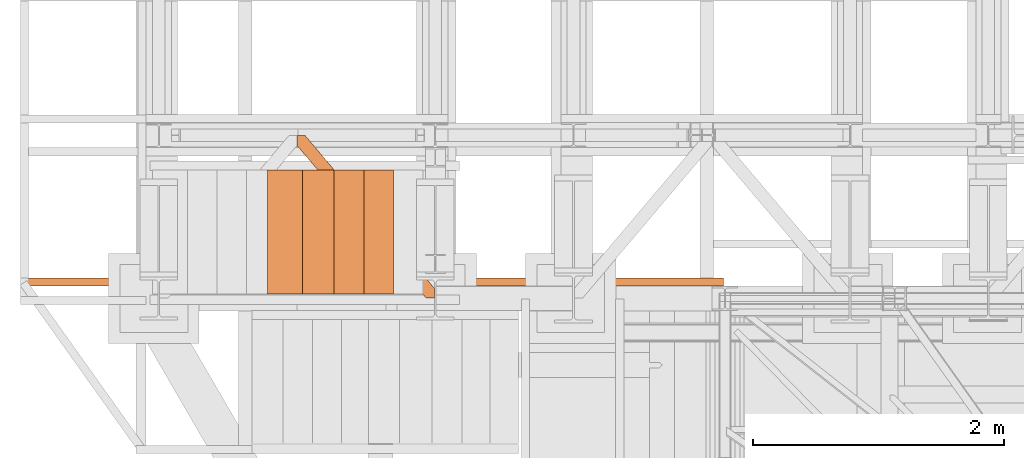
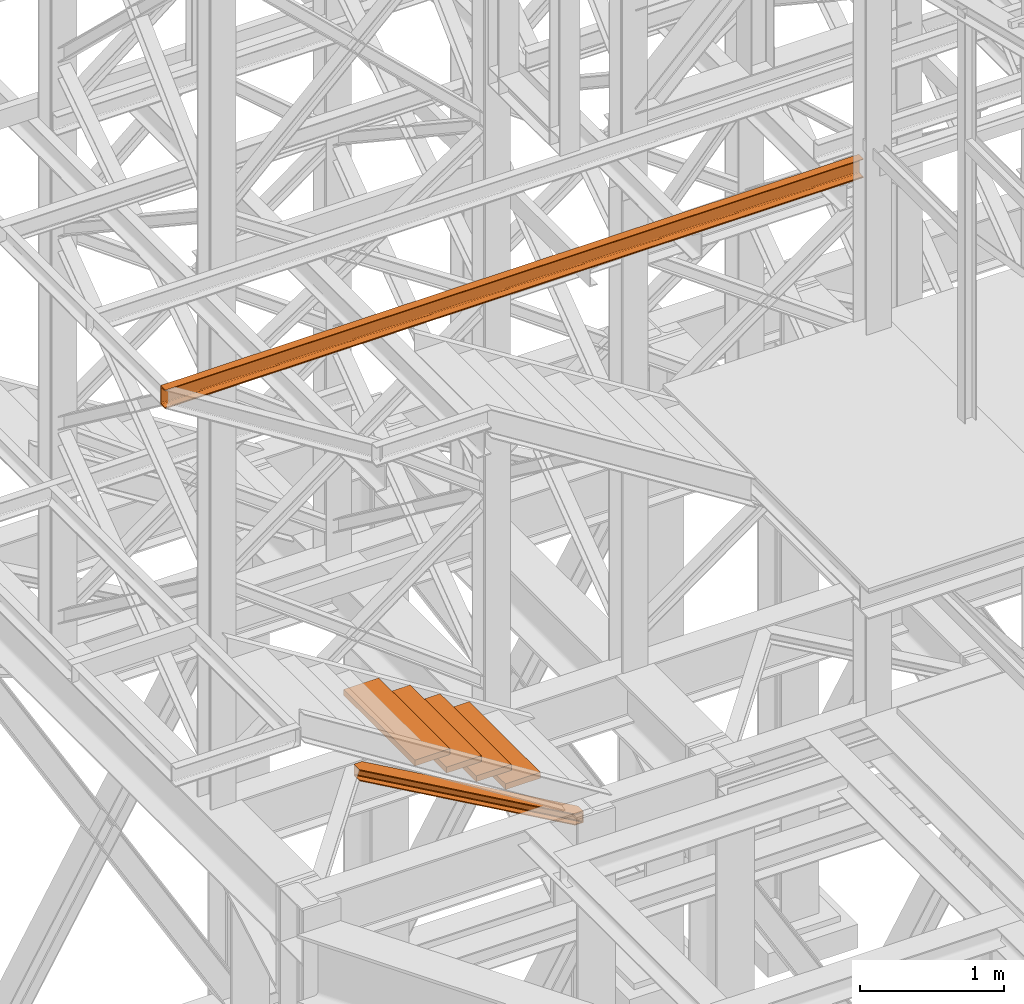
# One storey, part 85 of 208: 6 proxies.
"""IFC2X3 building model written with IfcOpenShell, lengths in millimetres."""

from ifc_helpers import new_model, entity, si_unit, converted_unit, frame, origin, origin_with_axes, place, context, subcontext, project, spatial, faceted_brep, element, save


model = new_model("IFC2X3")

# Units and contexts
model_context = context("Model", 3, precision=1e-05, world=origin())
plan_context = context("Plan", 3, precision=1e-05, world=origin())
body_context = subcontext(model_context, "Body", "Model", "MODEL_VIEW")
ifc_project = project(units=[si_unit("LENGTHUNIT", "METRE", prefix="MILLI"), converted_unit("PLANEANGLEUNIT", "DEGREE", entity("IfcPlaneAngleMeasure", 0.0174532925199433), si_unit("PLANEANGLEUNIT", "RADIAN"), dimensions=[0, 0, 0, 0, 0, 0, 0]), si_unit("AREAUNIT", "SQUARE_METRE"), si_unit("VOLUMEUNIT", "CUBIC_METRE")], contexts=[model_context, plan_context])

# Building, storey
building_placement = place(None, origin())
building = spatial("IfcBuilding", under=ifc_project, at=building_placement, CompositionType="COMPLEX")
storey_placement = place(building_placement, origin_with_axes())
storey = spatial("IfcBuildingStorey", under=building, at=storey_placement, Name="Geschoss", CompositionType="ELEMENT")

# Proxies
proxy_1_placement = place(storey_placement, frame((-2206.745031471333, -17257.87439359532, 5101.99001616488), z_axis=(0.0, 0.0, 1.0), x_axis=(1.0, 0.0, 0.0)))
element("IfcBuildingElementProxy", 1, at=proxy_1_placement, inside=storey, context=body_context, shape_type="Brep", body=[
    faceted_brep([(65.5076408449404, 1290.610003345233, 8.010001311303313), (65.5076408449404, 1290.610003345233, 0.01000000000112777), (1094.009999947835, 75.107215314536, 0.01000000000112777), (1094.009999947835, 75.107215314536, 8.010001311302403), (65.5076408449404, 1290.610003345233, 0.01000000000112777), (0.01000000000385626, 1290.610003345233, 0.01000000000112777), (0.01000000000385626, 1213.203700528486, 0.01000000000112777), (1026.558515831797, 0.01000000000203727, 0.01000000000021828), (1094.009999947835, 0.01000000000203727, 0.01000000000021828), (1094.009999947835, 75.107215314536, 0.01000000000112777), (0.01000000000385626, 1213.203700528486, 0.01000000000112777), (0.01000000000203727, 1213.203700528486, 8.010001311303313), (1026.558515831797, 0.01000000000203727, 8.010001311303313), (1026.558515831797, 0.01000000000203727, 0.01000000000021828), (0.01000000000203727, 1213.203700528486, 8.010001311303313), (0.01000000000385626, 1268.162175066997, 8.010001311303313), (1073.061840441307, 0.01000000000203727, 8.010001311303313), (1026.558515831797, 0.01000000000203727, 8.010001311303313), (0.01000000000385626, 1268.162175066997, 8.010001311303313), (0.01000000000385626, 1277.776874373873, 9.253033826352294), (1081.197355239432, 0.01000000000203727, 9.253033826352294), (1073.061840441307, 0.01000000000203727, 8.010001311303313), (0.01000000000385626, 1277.776874373873, 9.253033826352294), (0.01000000000385626, 1284.815317712282, 13.79946006298178), (1087.152961141163, 0.01000000000203727, 13.79946006298178), (1081.197355239432, 0.01000000000203727, 9.253033826352294), (0.01000000000385626, 1284.815317712282, 13.79946006298178), (0.01000000000385626, 1286.739687988122, 20.01000141561144), (1088.781274451489, 0.01000000000203727, 20.01000141561144), (1087.152961141163, 0.01000000000203727, 13.79946006298178), (0.01000000000385626, 1286.739687988122, 20.01000141561144), (0.01000000000385626, 1286.739687988122, 76.01000128150099), (1088.781274451489, 0.01000000000203727, 76.01000128150099), (1088.781274451489, 0.01000000000203727, 20.01000141561144), (0.01000000000385626, 1286.739687988122, 76.01000128150099), (0.01000000000385626, 1284.815317712282, 82.2205407714855), (1087.152961141163, 0.01000000000203727, 82.2205407714855), (1088.781274451489, 0.01000000000203727, 76.01000128150099), (0.01000000000385626, 1284.815317712282, 82.2205407714855), (0.01000000000385626, 1277.776874373873, 86.76696700811499), (1081.197355239432, 0.01000000000203727, 86.76696700811499), (1087.152961141163, 0.01000000000203727, 82.2205407714855), (0.01000000000385626, 1277.776874373873, 86.76696700811499), (0.01000000000385626, 1268.162175066997, 88.00999952316397), (1073.061840441305, 0.01000000000203727, 88.00999952316397), (1081.197355239432, 0.01000000000203727, 86.76696700811499), (0.01000000000385626, 1268.162175066997, 88.00999952316397), (0.01000000000385626, 1213.203700528486, 88.00999952316397), (1026.558515831797, 0.01000000000203727, 88.00999952316397), (1073.061840441305, 0.01000000000203727, 88.00999952316397), (0.01000000000385626, 1213.203700528486, 88.00999952316397), (0.01000000000021828, 1213.203700528487, 96.01000083446615), (1026.558515831797, 0.01000000000203727, 96.01000083446615), (1026.558515831797, 0.01000000000203727, 88.00999952316397), (0.01000000000021828, 1213.203700528487, 96.01000083446615), (0.01000000000203727, 1290.610003345233, 96.01000083446615), (65.5076408449404, 1290.610003345233, 96.01000083446615), (1094.009999947835, 75.107215314536, 96.01000083446615), (1094.009999947835, 0.01000000000203727, 96.01000083446615), (1026.558515831797, 0.01000000000203727, 96.01000083446615), (65.5076408449404, 1290.610003345233, 96.01000083446615), (65.5076408449404, 1290.610003345233, 88.00999952316397), (1094.009999947835, 75.107215314536, 88.00999952316397), (1094.009999947835, 75.107215314536, 96.01000083446615), (65.5076408449404, 1290.610003345233, 88.00999952316397), (19.00431623542863, 1290.610003345233, 88.00999952316397), (1094.009999947835, 20.14874077602508, 88.00999952316397), (1094.009999947835, 75.107215314536, 88.00999952316397), (19.00431623542863, 1290.610003345233, 88.00999952316397), (10.86880143730195, 1290.610003345233, 86.76696700811499), (1094.009999947835, 10.53404146914909, 86.76696700811499), (1094.009999947835, 20.14874077602508, 88.00999952316397), (10.86880143730195, 1290.610003345233, 86.76696700811499), (4.913195535573323, 1290.610003345233, 82.2205407714855), (1094.009999947835, 3.495598130743019, 82.2205407714855), (1094.009999947835, 10.53404146914909, 86.76696700811499), (4.913195535573323, 1290.610003345233, 82.2205407714855), (3.284882225247202, 1290.610003345233, 76.01000128150099), (1094.009999947835, 1.571227854899917, 76.01000128150099), (1094.009999947835, 3.495598130743019, 82.2205407714855), (3.284882225247202, 1290.610003345233, 76.01000128150099), (3.284882225247202, 1290.610003345233, 20.01000141561144), (1094.009999947835, 1.571227854899917, 20.01000141561144), (1094.009999947835, 1.571227854899917, 76.01000128150099), (3.284882225247202, 1290.610003345233, 20.01000141561144), (4.913195535573323, 1290.610003345233, 13.79946006298178), (1094.009999947835, 3.495598130743019, 13.79946006298178), (1094.009999947835, 1.571227854899917, 20.01000141561144), (4.913195535573323, 1290.610003345233, 13.79946006298178), (10.86880143730377, 1290.610003345233, 9.253033826352294), (1094.009999947835, 10.53404146914909, 9.253033826352294), (1094.009999947835, 3.495598130743019, 13.79946006298178), (10.86880143730377, 1290.610003345233, 9.253033826352294), (19.00431623543045, 1290.610003345233, 8.010001311303313), (1094.009999947835, 20.14874077602508, 8.010001311303313), (1094.009999947835, 10.53404146914909, 9.253033826352294), (19.00431623543045, 1290.610003345233, 8.010001311303313), (65.5076408449404, 1290.610003345233, 8.010001311303313), (1094.009999947835, 75.107215314536, 8.010001311302403), (1094.009999947835, 20.14874077602508, 8.010001311303313), (0.01000000000385626, 1213.203700528486, 0.01000000000112777), (0.01000000000385626, 1290.610003345233, 0.01000000000112777), (0.01000000000203727, 1290.610003345233, 96.01000083446615), (0.01000000000021828, 1213.203700528487, 96.01000083446615), (0.01000000000385626, 1213.203700528486, 88.00999952316397), (0.01000000000385626, 1268.162175066997, 88.00999952316397), (0.01000000000385626, 1277.776874373873, 86.76696700811499), (0.01000000000385626, 1284.815317712282, 82.2205407714855), (0.01000000000385626, 1286.739687988122, 76.01000128150099), (0.01000000000385626, 1286.739687988122, 20.01000141561144), (0.01000000000385626, 1284.815317712282, 13.79946006298178), (0.01000000000385626, 1277.776874373873, 9.253033826352294), (0.01000000000385626, 1268.162175066997, 8.010001311303313), (0.01000000000203727, 1213.203700528486, 8.010001311303313), (0.01000000000203727, 1290.610003345233, 96.01000083446615), (0.01000000000385626, 1290.610003345233, 0.01000000000112777), (65.5076408449404, 1290.610003345233, 0.01000000000112777), (65.5076408449404, 1290.610003345233, 8.010001311303313), (19.00431623543045, 1290.610003345233, 8.010001311303313), (10.86880143730377, 1290.610003345233, 9.253033826352294), (4.913195535573323, 1290.610003345233, 13.79946006298178), (3.284882225247202, 1290.610003345233, 20.01000141561144), (3.284882225247202, 1290.610003345233, 76.01000128150099), (4.913195535573323, 1290.610003345233, 82.2205407714855), (10.86880143730195, 1290.610003345233, 86.76696700811499), (19.00431623542863, 1290.610003345233, 88.00999952316397), (65.5076408449404, 1290.610003345233, 88.00999952316397), (65.5076408449404, 1290.610003345233, 96.01000083446615), (1094.009999947835, 75.107215314536, 8.010001311302403), (1094.009999947835, 75.107215314536, 0.01000000000112777), (1094.009999947835, 0.01000000000203727, 0.01000000000021828), (1094.009999947835, 0.01000000000203727, 96.01000083446615), (1094.009999947835, 75.107215314536, 96.01000083446615), (1094.009999947835, 75.107215314536, 88.00999952316397), (1094.009999947835, 20.14874077602508, 88.00999952316397), (1094.009999947835, 10.53404146914909, 86.76696700811499), (1094.009999947835, 3.495598130743019, 82.2205407714855), (1094.009999947835, 1.571227854899917, 76.01000128150099), (1094.009999947835, 1.571227854899917, 20.01000141561144), (1094.009999947835, 3.495598130743019, 13.79946006298178), (1094.009999947835, 10.53404146914909, 9.253033826352294), (1094.009999947835, 20.14874077602508, 8.010001311303313), (1094.009999947835, 0.01000000000203727, 0.01000000000021828), (1026.558515831797, 0.01000000000203727, 0.01000000000021828), (1026.558515831797, 0.01000000000203727, 8.010001311303313), (1073.061840441307, 0.01000000000203727, 8.010001311303313), (1081.197355239432, 0.01000000000203727, 9.253033826352294), (1087.152961141163, 0.01000000000203727, 13.79946006298178), (1088.781274451489, 0.01000000000203727, 20.01000141561144), (1088.781274451489, 0.01000000000203727, 76.01000128150099), (1087.152961141163, 0.01000000000203727, 82.2205407714855), (1081.197355239432, 0.01000000000203727, 86.76696700811499), (1073.061840441305, 0.01000000000203727, 88.00999952316397), (1026.558515831797, 0.01000000000203727, 88.00999952316397), (1026.558515831797, 0.01000000000203727, 96.01000083446615), (1094.009999947835, 0.01000000000203727, 96.01000083446615)], [[[0, 1, 2, 3]], [[4, 5, 6, 7, 8, 9]], [[10, 11, 12, 13]], [[14, 15, 16, 17]], [[18, 19, 20, 21]], [[22, 23, 24, 25]], [[26, 27, 28, 29]], [[30, 31, 32, 33]], [[34, 35, 36, 37]], [[38, 39, 40, 41]], [[42, 43, 44, 45]], [[46, 47, 48, 49]], [[50, 51, 52, 53]], [[54, 55, 56, 57, 58, 59]], [[60, 61, 62, 63]], [[64, 65, 66, 67]], [[68, 69, 70, 71]], [[72, 73, 74, 75]], [[76, 77, 78, 79]], [[80, 81, 82, 83]], [[84, 85, 86, 87]], [[88, 89, 90, 91]], [[92, 93, 94, 95]], [[96, 97, 98, 99]], [[100, 101, 102, 103, 104, 105, 106, 107, 108, 109, 110, 111, 112, 113]], [[114, 115, 116, 117, 118, 119, 120, 121, 122, 123, 124, 125, 126, 127]], [[128, 129, 130, 131, 132, 133, 134, 135, 136, 137, 138, 139, 140, 141]], [[142, 143, 144, 145, 146, 147, 148, 149, 150, 151, 152, 153, 154, 155]]], orient=[[False], [False], [False], [False], [False], [False], [False], [False], [False], [False], [False], [False], [False], [False], [False], [False], [False], [False], [False], [False], [False], [False], [False], [False], [False], [False], [False], [False]]),
])
proxy_2_placement = place(storey_placement, frame((-2191.97451080468, -17228.55346893691, 5880.987947857569), z_axis=(0.0, 0.0, 1.0), x_axis=(1.0, 0.0, 0.0)))
element("IfcBuildingElementProxy", 2, at=proxy_2_placement, inside=storey, context=body_context, shape_type="Brep", body=[
    faceted_brep([(0.009999999999763531, 0.00999999999839929, 0.01000000000021828), (280.2746556316172, 0.00999999999839929, 0.01000000000021828), (280.2746556316172, 988.9080206708568, 0.01000000000021828), (0.009999999999763531, 988.9080206708568, 0.01000000000021828), (280.2746556316172, 0.00999999999839929, 50.01000000000022), (0.009999999999763531, 0.00999999999839929, 50.01000000000022), (0.009999999999763531, 988.9080206708568, 50.01000000000022), (280.2746556316172, 988.9080206708568, 50.01000000000022), (280.2746556316172, 0.00999999999839929, 0.01000000000021828), (0.009999999999763531, 0.00999999999839929, 0.01000000000021828), (0.009999999999763531, 0.00999999999839929, 50.01000000000022), (280.2746556316172, 0.00999999999839929, 50.01000000000022), (280.2746556316172, 988.9080206708568, 0.01000000000021828), (280.2746556316172, 0.00999999999839929, 0.01000000000021828), (280.2746556316172, 0.00999999999839929, 50.01000000000022), (280.2746556316172, 988.9080206708568, 50.01000000000022), (0.009999999999763531, 988.9080206708568, 0.01000000000021828), (280.2746556316172, 988.9080206708568, 0.01000000000021828), (280.2746556316172, 988.9080206708568, 50.01000000000022), (0.009999999999763531, 988.9080206708568, 50.01000000000022), (0.009999999999763531, 0.00999999999839929, 0.01000000000021828), (0.009999999999763531, 988.9080206708568, 0.01000000000021828), (0.009999999999763531, 988.9080206708568, 50.01000000000022), (0.009999999999763531, 0.00999999999839929, 50.01000000000022)], [[[0, 1, 2, 3]], [[4, 5, 6, 7]], [[8, 9, 10, 11]], [[12, 13, 14, 15]], [[16, 17, 18, 19]], [[20, 21, 22, 23]]], orient=[[False], [False], [False], [False], [False], [False]]),
])
proxy_3_placement = place(storey_placement, frame((-1953.400600323233, -17228.55346893691, 5723.648884501375), z_axis=(0.0, 0.0, 1.0), x_axis=(1.0, 0.0, 0.0)))
element("IfcBuildingElementProxy", 3, at=proxy_3_placement, inside=storey, context=body_context, shape_type="Brep", body=[
    faceted_brep([(0.009999999999990905, 0.00999999999839929, 0.01000000000021828), (280.2746556316176, 0.00999999999839929, 0.01000000000021828), (280.2746556316176, 988.9080206708568, 0.01000000000021828), (0.009999999999990905, 988.9080206708568, 0.01000000000021828), (280.2746556316176, 0.00999999999839929, 50.01000000000022), (0.009999999999990905, 0.00999999999839929, 50.01000000000022), (0.009999999999990905, 988.9080206708568, 50.01000000000022), (280.2746556316176, 988.9080206708568, 50.01000000000022), (280.2746556316176, 0.00999999999839929, 0.01000000000021828), (0.009999999999990905, 0.00999999999839929, 0.01000000000021828), (0.009999999999990905, 0.00999999999839929, 50.01000000000022), (280.2746556316176, 0.00999999999839929, 50.01000000000022), (280.2746556316176, 988.9080206708568, 0.01000000000021828), (280.2746556316176, 0.00999999999839929, 0.01000000000021828), (280.2746556316176, 0.00999999999839929, 50.01000000000022), (280.2746556316176, 988.9080206708568, 50.01000000000022), (0.009999999999990905, 988.9080206708568, 0.01000000000021828), (280.2746556316176, 988.9080206708568, 0.01000000000021828), (280.2746556316176, 988.9080206708568, 50.01000000000022), (0.009999999999990905, 988.9080206708568, 50.01000000000022), (0.009999999999990905, 0.00999999999839929, 0.01000000000021828), (0.009999999999990905, 988.9080206708568, 0.01000000000021828), (0.009999999999990905, 988.9080206708568, 50.01000000000022), (0.009999999999990905, 0.00999999999839929, 50.01000000000022)], [[[0, 1, 2, 3]], [[4, 5, 6, 7]], [[8, 9, 10, 11]], [[12, 13, 14, 15]], [[16, 17, 18, 19]], [[20, 21, 22, 23]]], orient=[[False], [False], [False], [False], [False], [False]]),
])
proxy_4_placement = place(storey_placement, frame((-2444.709211129622, -17228.55346893691, 6029.15245398457), z_axis=(0.0, 0.0, 1.0), x_axis=(1.0, 0.0, 0.0)))
element("IfcBuildingElementProxy", 4, at=proxy_4_placement, inside=storey, context=body_context, shape_type="Brep", body=[
    faceted_brep([(0.01000000000021828, 0.00999999999839929, 0.01000000000021828), (280.2746556316179, 0.00999999999839929, 0.01000000000021828), (280.2746556316179, 988.9080206708568, 0.01000000000021828), (0.01000000000021828, 988.9080206708568, 0.01000000000021828), (280.2746556316179, 0.00999999999839929, 50.01000000000022), (0.01000000000021828, 0.00999999999839929, 50.01000000000022), (0.01000000000021828, 988.9080206708568, 50.01000000000022), (280.2746556316179, 988.9080206708568, 50.01000000000022), (280.2746556316179, 0.00999999999839929, 0.01000000000021828), (0.01000000000021828, 0.00999999999839929, 0.01000000000021828), (0.01000000000021828, 0.00999999999839929, 50.01000000000022), (280.2746556316179, 0.00999999999839929, 50.01000000000022), (280.2746556316179, 988.9080206708568, 0.01000000000021828), (280.2746556316179, 0.00999999999839929, 0.01000000000021828), (280.2746556316179, 0.00999999999839929, 50.01000000000022), (280.2746556316179, 988.9080206708568, 50.01000000000022), (0.01000000000021828, 988.9080206708568, 0.01000000000021828), (280.2746556316179, 988.9080206708568, 0.01000000000021828), (280.2746556316179, 988.9080206708568, 50.01000000000022), (0.01000000000021828, 988.9080206708568, 50.01000000000022), (0.01000000000021828, 0.00999999999839929, 0.01000000000021828), (0.01000000000021828, 988.9080206708568, 0.01000000000021828), (0.01000000000021828, 988.9080206708568, 50.01000000000022), (0.01000000000021828, 0.00999999999839929, 50.01000000000022)], [[[0, 1, 2, 3]], [[4, 5, 6, 7]], [[8, 9, 10, 11]], [[12, 13, 14, 15]], [[16, 17, 18, 19]], [[20, 21, 22, 23]]], orient=[[False], [False], [False], [False], [False], [False]]),
])
proxy_5_placement = place(storey_placement, frame((-1720.329412323669, -17228.55346893691, 5574.778373538034), z_axis=(0.0, 0.0, 1.0), x_axis=(1.0, 0.0, 0.0)))
element("IfcBuildingElementProxy", 5, at=proxy_5_placement, inside=storey, context=body_context, shape_type="Brep", body=[
    faceted_brep([(0.009999999999990905, 0.00999999999839929, 0.01000000000021828), (280.2746556316176, 0.00999999999839929, 0.01000000000021828), (280.2746556316176, 988.9080206708568, 0.01000000000021828), (0.009999999999990905, 988.9080206708568, 0.01000000000021828), (280.2746556316176, 0.00999999999839929, 50.01000000000022), (0.009999999999990905, 0.00999999999839929, 50.01000000000022), (0.009999999999990905, 988.9080206708568, 50.01000000000022), (280.2746556316176, 988.9080206708568, 50.01000000000022), (280.2746556316176, 0.00999999999839929, 0.01000000000021828), (0.009999999999990905, 0.00999999999839929, 0.01000000000021828), (0.009999999999990905, 0.00999999999839929, 50.01000000000022), (280.2746556316176, 0.00999999999839929, 50.01000000000022), (280.2746556316176, 988.9080206708568, 0.01000000000021828), (280.2746556316176, 0.00999999999839929, 0.01000000000021828), (280.2746556316176, 0.00999999999839929, 50.01000000000022), (280.2746556316176, 988.9080206708568, 50.01000000000022), (0.009999999999990905, 988.9080206708568, 0.01000000000021828), (280.2746556316176, 988.9080206708568, 0.01000000000021828), (280.2746556316176, 988.9080206708568, 50.01000000000022), (0.009999999999990905, 988.9080206708568, 50.01000000000022), (0.009999999999990905, 0.00999999999839929, 0.01000000000021828), (0.009999999999990905, 988.9080206708568, 0.01000000000021828), (0.009999999999990905, 988.9080206708568, 50.01000000000022), (0.009999999999990905, 0.00999999999839929, 50.01000000000022)], [[[0, 1, 2, 3]], [[4, 5, 6, 7]], [[8, 9, 10, 11]], [[12, 13, 14, 15]], [[16, 17, 18, 19]], [[20, 21, 22, 23]]], orient=[[False], [False], [False], [False], [False], [False]]),
])
proxy_6_placement = place(storey_placement, frame((-4406.745032961453, -17162.574391808, 9699.99), z_axis=(0.0, 0.0, 1.0), x_axis=(1.0, 0.0, 0.0)))
element("IfcBuildingElementProxy", 6, at=proxy_6_placement, inside=storey, context=body_context, shape_type="Brep", body=[
    faceted_brep([(0.01000000000021828, 0.00999999999839929, 0.01000000000021828), (0.01000000000021828, 0.00999999999839929, 3.132428070246533), (5592.010002086164, 0.00999999999839929, 3.132428070246533), (5592.010002086164, 0.00999999999839929, 0.01000000000021828), (0.01000000000021828, 0.00999999999839929, 3.132428070246533), (0.01000000000021828, 0.2527365771748009, 4.748288908171162), (5592.010002086164, 0.2527365771711629, 4.748288908171162), (5592.010002086164, 0.00999999999839929, 3.132428070246533), (0.01000000000021828, 0.2527365771748009, 4.748288908171162), (0.01000000000021828, 0.9594677141431021, 6.221534443444398), (5592.010002086164, 0.9594677141431021, 6.221534443444398), (5592.010002086164, 0.2527365771711629, 4.748288908171162), (0.01000000000021828, 0.9594677141431021, 6.221534443444398), (0.01000000000021828, 2.067848361530196, 7.422126703873801), (5592.010002086164, 2.067848361530196, 7.422126703873801), (5592.010002086164, 0.9594677141431021, 6.221534443444398), (0.01000000000021828, 2.067848361530196, 7.422126703873801), (0.01000000000021828, 3.4800435885154, 8.244091391710754), (5592.010002086164, 3.4800435885154, 8.244091391710754), (5592.010002086164, 2.067848361530196, 7.422126703873801), (0.01000000000021828, 3.4800435885154, 8.244091391710754), (0.01000000000021828, 5.071401277444238, 8.614912102195376), (5592.010002086164, 5.071401277444238, 8.614912102195376), (5592.010002086164, 3.4800435885154, 8.244091391710754), (0.01000000000021828, 5.071401277444238, 8.614912102195376), (0.01000000000021828, 47.84732483396874, 12.0369859867169), (5592.010002086164, 47.84732483396874, 12.0369859867169), (5592.010002086164, 5.071401277444238, 8.614912102195376), (0.01000000000021828, 47.84732483396874, 12.0369859867169), (0.01000000000021828, 50.88537133101636, 12.74491643400506), (5592.010002086164, 50.88537133101636, 12.74491643400506), (5592.010002086164, 47.84732483396874, 12.0369859867169), (0.01000000000021828, 50.88537133101636, 12.74491643400506), (0.01000000000021828, 53.58138040071208, 14.31412174714933), (5592.010002086164, 53.58138040071208, 14.31412174714933), (5592.010002086164, 50.88537133101636, 12.74491643400506), (0.01000000000021828, 53.58138040071208, 14.31412174714933), (0.01000000000021828, 55.69737981845174, 16.60616151705835), (5592.010002086164, 55.69737981845174, 16.60616151705835), (5592.010002086164, 53.58138040071208, 14.31412174714933), (0.01000000000021828, 55.69737981845174, 16.60616151705835), (0.01000000000021828, 57.04659380721569, 19.41872117530875), (5592.010002086164, 57.04659380721205, 19.41872117530875), (5592.010002086164, 55.69737981845174, 16.60616151705835), (0.01000000000021828, 57.04659380721569, 19.41872117530875), (0.01000000000021828, 57.5099999999984, 22.50354641134618), (5592.010002086164, 57.5099999999984, 22.50354641134618), (5592.010002086164, 57.04659380721205, 19.41872117530875), (0.01000000000021828, 57.5099999999984, 22.50354641134618), (0.01000000000021828, 57.5099999999984, 137.5164535886524), (5592.010002086164, 57.5099999999984, 137.5164535886524), (5592.010002086164, 57.5099999999984, 22.50354641134618), (0.01000000000021828, 57.5099999999984, 137.5164535886524), (0.01000000000021828, 57.04659380721569, 140.6012788246917), (5592.010002086164, 57.04659380721205, 140.6012788246917), (5592.010002086164, 57.5099999999984, 137.5164535886524), (0.01000000000021828, 57.04659380721569, 140.6012788246917), (0.01000000000021828, 55.69737981845174, 143.4138384829403), (5592.010002086164, 55.69737981845174, 143.4138384829403), (5592.010002086164, 57.04659380721205, 140.6012788246917), (0.01000000000021828, 55.69737981845174, 143.4138384829403), (0.01000000000021828, 53.58138040071208, 145.7058782528493), (5592.010002086164, 53.58138040071208, 145.7058782528493), (5592.010002086164, 55.69737981845174, 143.4138384829403), (0.01000000000021828, 53.58138040071208, 145.7058782528493), (0.01000000000021828, 50.88537133101636, 147.2750835659936), (5592.010002086164, 50.88537133101636, 147.2750835659936), (5592.010002086164, 53.58138040071208, 145.7058782528493), (0.01000000000021828, 50.88537133101636, 147.2750835659936), (0.01000000000021828, 47.84732483396874, 147.9830140132817), (5592.010002086164, 47.84732483396874, 147.9830140132817), (5592.010002086164, 50.88537133101636, 147.2750835659936), (0.01000000000021828, 47.84732483396874, 147.9830140132817), (0.01000000000021828, 5.071401277444238, 151.4050878978032), (5592.010002086164, 5.071401277444238, 151.4050878978032), (5592.010002086164, 47.84732483396874, 147.9830140132817), (0.01000000000021828, 5.071401277444238, 151.4050878978032), (0.01000000000021828, 3.4800435885154, 151.7759086082879), (5592.010002086164, 3.4800435885154, 151.7759086082879), (5592.010002086164, 5.071401277444238, 151.4050878978032), (0.01000000000021828, 3.4800435885154, 151.7759086082879), (0.01000000000021828, 2.067848361530196, 152.5978732961248), (5592.010002086164, 2.067848361530196, 152.5978732961248), (5592.010002086164, 3.4800435885154, 151.7759086082879), (0.01000000000021828, 2.067848361530196, 152.5978732961248), (0.01000000000021828, 0.9594677141431021, 153.7984655565542), (5592.010002086164, 0.9594677141431021, 153.7984655565542), (5592.010002086164, 2.067848361530196, 152.5978732961248), (0.01000000000021828, 0.9594677141431021, 153.7984655565542), (0.01000000000021828, 0.2527365771748009, 155.2717110918275), (5592.010002086164, 0.2527365771711629, 155.2717110918275), (5592.010002086164, 0.9594677141431021, 153.7984655565542), (0.01000000000021828, 0.2527365771748009, 155.2717110918275), (0.01000000000021828, 0.00999999999839929, 156.8875719297521), (5592.010002086164, 0.00999999999839929, 156.8875719297521), (5592.010002086164, 0.2527365771711629, 155.2717110918275), (0.01000000000021828, 0.00999999999839929, 156.8875719297521), (0.01000000000021828, 0.00999999999839929, 160.0100000000002), (5592.010002086164, 0.00999999999839929, 160.0100000000002), (5592.010002086164, 0.00999999999839929, 156.8875719297521), (0.01000000000021828, 0.00999999999839929, 160.0100000000002), (0.01000000000021828, 65.0099999999984, 160.0100000000002), (5592.010002086164, 65.0099999999984, 160.0100000000002), (5592.010002086164, 0.00999999999839929, 160.0100000000002), (0.01000000000021828, 65.0099999999984, 160.0100000000002), (0.01000000000021828, 65.0099999999984, 0.01000000000021828), (5592.010002086164, 65.0099999999984, 0.01000000000021828), (5592.010002086164, 65.0099999999984, 160.0100000000002), (0.01000000000021828, 65.0099999999984, 0.01000000000021828), (0.01000000000021828, 0.00999999999839929, 0.01000000000021828), (5592.010002086164, 0.00999999999839929, 0.01000000000021828), (5592.010002086164, 65.0099999999984, 0.01000000000021828), (0.01000000000021828, 0.00999999999839929, 0.01000000000021828), (0.01000000000021828, 65.0099999999984, 0.01000000000021828), (0.01000000000021828, 65.0099999999984, 160.0100000000002), (0.01000000000021828, 0.00999999999839929, 160.0100000000002), (0.01000000000021828, 0.00999999999839929, 156.8875719297521), (0.01000000000021828, 0.2527365771748009, 155.2717110918275), (0.01000000000021828, 0.9594677141431021, 153.7984655565542), (0.01000000000021828, 2.067848361530196, 152.5978732961248), (0.01000000000021828, 3.4800435885154, 151.7759086082879), (0.01000000000021828, 5.071401277444238, 151.4050878978032), (0.01000000000021828, 47.84732483396874, 147.9830140132817), (0.01000000000021828, 50.88537133101636, 147.2750835659936), (0.01000000000021828, 53.58138040071208, 145.7058782528493), (0.01000000000021828, 55.69737981845174, 143.4138384829403), (0.01000000000021828, 57.04659380721569, 140.6012788246917), (0.01000000000021828, 57.5099999999984, 137.5164535886524), (0.01000000000021828, 57.5099999999984, 22.50354641134618), (0.01000000000021828, 57.04659380721569, 19.41872117530875), (0.01000000000021828, 55.69737981845174, 16.60616151705835), (0.01000000000021828, 53.58138040071208, 14.31412174714933), (0.01000000000021828, 50.88537133101636, 12.74491643400506), (0.01000000000021828, 47.84732483396874, 12.0369859867169), (0.01000000000021828, 5.071401277444238, 8.614912102195376), (0.01000000000021828, 3.4800435885154, 8.244091391710754), (0.01000000000021828, 2.067848361530196, 7.422126703873801), (0.01000000000021828, 0.9594677141431021, 6.221534443444398), (0.01000000000021828, 0.2527365771748009, 4.748288908171162), (0.01000000000021828, 0.00999999999839929, 3.132428070246533), (5592.010002086164, 0.00999999999839929, 0.01000000000021828), (5592.010002086164, 0.00999999999839929, 3.132428070246533), (5592.010002086164, 0.2527365771711629, 4.748288908171162), (5592.010002086164, 0.9594677141431021, 6.221534443444398), (5592.010002086164, 2.067848361530196, 7.422126703873801), (5592.010002086164, 3.4800435885154, 8.244091391710754), (5592.010002086164, 5.071401277444238, 8.614912102195376), (5592.010002086164, 47.84732483396874, 12.0369859867169), (5592.010002086164, 50.88537133101636, 12.74491643400506), (5592.010002086164, 53.58138040071208, 14.31412174714933), (5592.010002086164, 55.69737981845174, 16.60616151705835), (5592.010002086164, 57.04659380721205, 19.41872117530875), (5592.010002086164, 57.5099999999984, 22.50354641134618), (5592.010002086164, 57.5099999999984, 137.5164535886524), (5592.010002086164, 57.04659380721205, 140.6012788246917), (5592.010002086164, 55.69737981845174, 143.4138384829403), (5592.010002086164, 53.58138040071208, 145.7058782528493), (5592.010002086164, 50.88537133101636, 147.2750835659936), (5592.010002086164, 47.84732483396874, 147.9830140132817), (5592.010002086164, 5.071401277444238, 151.4050878978032), (5592.010002086164, 3.4800435885154, 151.7759086082879), (5592.010002086164, 2.067848361530196, 152.5978732961248), (5592.010002086164, 0.9594677141431021, 153.7984655565542), (5592.010002086164, 0.2527365771711629, 155.2717110918275), (5592.010002086164, 0.00999999999839929, 156.8875719297521), (5592.010002086164, 0.00999999999839929, 160.0100000000002), (5592.010002086164, 65.0099999999984, 160.0100000000002), (5592.010002086164, 65.0099999999984, 0.01000000000021828)], [[[0, 1, 2, 3]], [[4, 5, 6, 7]], [[8, 9, 10, 11]], [[12, 13, 14, 15]], [[16, 17, 18, 19]], [[20, 21, 22, 23]], [[24, 25, 26, 27]], [[28, 29, 30, 31]], [[32, 33, 34, 35]], [[36, 37, 38, 39]], [[40, 41, 42, 43]], [[44, 45, 46, 47]], [[48, 49, 50, 51]], [[52, 53, 54, 55]], [[56, 57, 58, 59]], [[60, 61, 62, 63]], [[64, 65, 66, 67]], [[68, 69, 70, 71]], [[72, 73, 74, 75]], [[76, 77, 78, 79]], [[80, 81, 82, 83]], [[84, 85, 86, 87]], [[88, 89, 90, 91]], [[92, 93, 94, 95]], [[96, 97, 98, 99]], [[100, 101, 102, 103]], [[104, 105, 106, 107]], [[108, 109, 110, 111]], [[112, 113, 114, 115, 116, 117, 118, 119, 120, 121, 122, 123, 124, 125, 126, 127, 128, 129, 130, 131, 132, 133, 134, 135, 136, 137, 138, 139]], [[140, 141, 142, 143, 144, 145, 146, 147, 148, 149, 150, 151, 152, 153, 154, 155, 156, 157, 158, 159, 160, 161, 162, 163, 164, 165, 166, 167]]], orient=[[False], [False], [False], [False], [False], [False], [False], [False], [False], [False], [False], [False], [False], [False], [False], [False], [False], [False], [False], [False], [False], [False], [False], [False], [False], [False], [False], [False], [False], [False]]),
])

save(model, "model.ifc")
